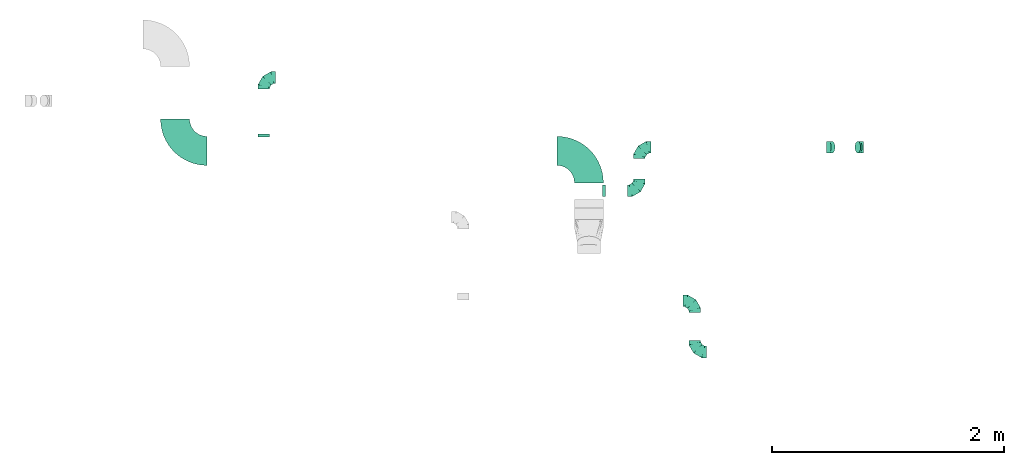
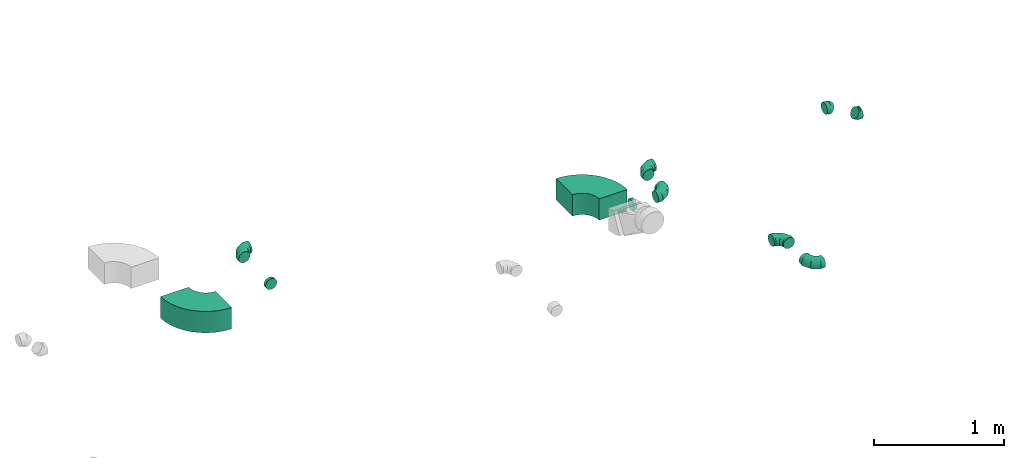
# One storey, part 26 of 32: 11 flow fittings.
"""IFC2X3 building model written with IfcOpenShell, lengths in millimetres."""

from ifc_helpers import new_model, entity, si_unit, converted_unit, derived_unit, direction, frame, frame_2d, origin, place, context, subcontext, project, spatial, polyline, circle_curve, parameter, trimmed, segment, composite_curve, outline, extrude, faceted_brep, source, transform, mapped, material, type_object, type_shapes, element, save


model = new_model("IFC2X3")

# Units and contexts
model_context = context("Model", 3, precision=0.01, world=origin(), true_north=direction((6.12303176911189e-17, 1.0)))
body_context = subcontext(model_context, "Body", "Model", "MODEL_VIEW")
ifc_project = project(units=[si_unit("LENGTHUNIT", "METRE", prefix="MILLI"), si_unit("AREAUNIT", "SQUARE_METRE"), si_unit("VOLUMEUNIT", "CUBIC_METRE"), converted_unit("PLANEANGLEUNIT", "DEGREE", entity("IfcRatioMeasure", 0.0174532925199433), si_unit("PLANEANGLEUNIT", "RADIAN"), dimensions=[0, 0, 0, 0, 0, 0, 0]), si_unit("MASSUNIT", "GRAM", prefix="KILO"), derived_unit("MASSDENSITYUNIT", [(si_unit("MASSUNIT", "GRAM", prefix="KILO"), 1), (si_unit("LENGTHUNIT", "METRE"), -3)]), derived_unit("MOMENTOFINERTIAUNIT", [(si_unit("LENGTHUNIT", "METRE"), 4)]), si_unit("TIMEUNIT", "SECOND"), si_unit("FREQUENCYUNIT", "HERTZ"), si_unit("THERMODYNAMICTEMPERATUREUNIT", "DEGREE_CELSIUS"), derived_unit("THERMALTRANSMITTANCEUNIT", [(si_unit("MASSUNIT", "GRAM", prefix="KILO"), 1), (si_unit("THERMODYNAMICTEMPERATUREUNIT", "KELVIN"), -1), (si_unit("TIMEUNIT", "SECOND"), -3)]), derived_unit("VOLUMETRICFLOWRATEUNIT", [(si_unit("LENGTHUNIT", "METRE"), 3), (si_unit("TIMEUNIT", "SECOND"), -1)]), derived_unit("MASSFLOWRATEUNIT", [(si_unit("MASSUNIT", "GRAM", prefix="KILO"), 1), (si_unit("TIMEUNIT", "SECOND"), -1)]), derived_unit("ROTATIONALFREQUENCYUNIT", [(si_unit("TIMEUNIT", "SECOND"), -1)]), si_unit("ELECTRICCURRENTUNIT", "AMPERE"), si_unit("ELECTRICVOLTAGEUNIT", "VOLT"), si_unit("POWERUNIT", "WATT"), si_unit("FORCEUNIT", "NEWTON", prefix="KILO"), si_unit("ILLUMINANCEUNIT", "LUX"), si_unit("LUMINOUSFLUXUNIT", "LUMEN"), si_unit("LUMINOUSINTENSITYUNIT", "CANDELA"), derived_unit("USERDEFINED", [(si_unit("MASSUNIT", "GRAM", prefix="KILO"), -1), (si_unit("LENGTHUNIT", "METRE"), -2), (si_unit("TIMEUNIT", "SECOND"), 3), (si_unit("LUMINOUSFLUXUNIT", "LUMEN"), 1)]), derived_unit("LINEARVELOCITYUNIT", [(si_unit("LENGTHUNIT", "METRE"), 1), (si_unit("TIMEUNIT", "SECOND"), -1)]), si_unit("PRESSUREUNIT", "PASCAL"), derived_unit("USERDEFINED", [(si_unit("LENGTHUNIT", "METRE"), -2), (si_unit("MASSUNIT", "GRAM", prefix="KILO"), 1), (si_unit("TIMEUNIT", "SECOND"), -2)]), derived_unit("LINEARFORCEUNIT", [(si_unit("MASSUNIT", "GRAM", prefix="KILO"), 1), (si_unit("LENGTHUNIT", "METRE"), 1), (si_unit("TIMEUNIT", "SECOND"), -2), (si_unit("LENGTHUNIT", "METRE"), -1)]), derived_unit("PLANARFORCEUNIT", [(si_unit("MASSUNIT", "GRAM", prefix="KILO"), 1), (si_unit("LENGTHUNIT", "METRE"), 1), (si_unit("TIMEUNIT", "SECOND"), -2), (si_unit("LENGTHUNIT", "METRE"), -2)])], contexts=[model_context])

# Site, building, storey
site_placement = place(None, origin())
site = spatial("IfcSite", under=ifc_project, at=site_placement, CompositionType="ELEMENT")
building_placement = place(site_placement, origin())
building = spatial("IfcBuilding", under=site, at=building_placement, CompositionType="ELEMENT")
storey_placement = place(building_placement, frame((0.0, 0.0, 8100.0)))
storey = spatial("IfcBuildingStorey", under=building, at=storey_placement, CompositionType="ELEMENT", Elevation=8100.0)

# Flow fittings
ifc_material = material()
duct_fitting_type_1 = type_object("IfcDuctFittingType", PredefinedType="NOTDEFINED", material=ifc_material)
shared_shape_1 = source(origin(), body_context, "Body", "Brep", [
    faceted_brep([(-100.0, 0.0, -50.0), (-100.0, -12.94, -48.3), (-100.0, -25.0, -43.3), (-100.0, -35.36, -35.36), (-100.0, -43.3, -25.0), (-100.0, -48.3, -12.94), (-100.0, -50.0, 0.0), (-100.0, -48.3, 12.94), (-100.0, -43.3, 25.0), (-100.0, -35.36, 35.36), (-100.0, -25.0, 43.3), (-100.0, -12.94, 48.3), (-100.0, 0.0, 50.0), (-100.0, 12.94, 48.3), (-100.0, 25.0, 43.3), (-100.0, 35.36, 35.36), (-100.0, 43.3, 25.0), (-100.0, 48.3, 12.94), (-100.0, 50.0, 0.0), (-100.0, 48.3, -12.94), (-100.0, 43.3, -25.0), (-100.0, 35.36, -35.36), (-100.0, 25.0, -43.3), (-100.0, 12.94, -48.3), (-76.67, 12.94, 48.3), (-79.9, 25.0, 43.3), (-73.21, 0.0, 50.0), (-82.68, 35.36, 35.36), (-86.15, 48.3, 12.94), (-86.6, 50.0, 0.0), (-84.81, 43.3, 25.0), (-84.81, 43.3, -25.0), (-82.68, 35.36, -35.36), (-86.15, 48.3, -12.94), (-76.67, 12.94, -48.3), (-73.21, 0.0, -50.0), (-79.9, 25.0, -43.3), (-69.74, -12.94, -48.3), (-66.51, -25.0, -43.3), (-63.73, -35.36, -35.36), (-61.6, -43.3, -25.0), (-60.26, -48.3, -12.94), (-59.81, -50.0, 0.0), (-60.26, -48.3, 12.94), (-61.6, -43.3, 25.0), (-63.73, -35.36, 35.36), (-66.51, -25.0, 43.3), (-69.74, -12.94, 48.3), (-36.27, 36.27, 48.3), (-45.1, 45.1, 43.3), (-26.79, 26.79, 50.0), (-52.68, 52.68, 35.36), (-58.49, 58.49, 25.0), (-62.15, 62.15, 12.94), (-63.4, 63.4, 0.0), (-62.15, 62.15, -12.94), (-58.49, 58.49, -25.0), (-52.68, 52.68, -35.36), (-36.27, 36.27, -48.3), (-26.79, 26.79, -50.0), (-45.1, 45.1, -43.3), (-17.32, 17.32, -48.3), (-8.49, 8.49, -43.3), (-0.91, 0.91, -35.36), (4.9, -4.9, -25.0), (8.56, -8.56, -12.94), (9.81, -9.81, 0.0), (8.56, -8.56, 12.94), (4.9, -4.9, 25.0), (-0.91, 0.91, 35.36), (-8.49, 8.49, 43.3), (-17.32, 17.32, 48.3), (-12.94, 76.67, 48.3), (-25.0, 79.9, 43.3), (0.0, 73.21, 50.0), (-35.36, 82.68, 35.36), (-43.3, 84.81, 25.0), (-48.3, 86.15, 12.94), (-50.0, 86.6, 0.0), (-48.3, 86.15, -12.94), (-43.3, 84.81, -25.0), (-35.36, 82.68, -35.36), (-12.94, 76.67, -48.3), (0.0, 73.21, -50.0), (-25.0, 79.9, -43.3), (12.94, 69.74, -48.3), (25.0, 66.51, -43.3), (35.36, 63.73, -35.36), (43.3, 61.6, -25.0), (48.3, 60.26, -12.94), (50.0, 59.81, 0.0), (48.3, 60.26, 12.94), (43.3, 61.6, 25.0), (35.36, 63.73, 35.36), (25.0, 66.51, 43.3), (12.94, 69.74, 48.3), (-12.94, 100.0, -48.3), (-25.0, 100.0, -43.3), (-35.36, 100.0, -35.36), (-43.3, 100.0, -25.0), (-48.3, 100.0, -12.94), (-50.0, 100.0, 0.0), (-48.3, 100.0, 12.94), (-43.3, 100.0, 25.0), (-35.36, 100.0, 35.36), (-25.0, 100.0, 43.3), (-12.94, 100.0, 48.3), (0.0, 100.0, 50.0), (12.94, 100.0, 48.3), (25.0, 100.0, 43.3), (35.36, 100.0, 35.36), (43.3, 100.0, 25.0), (48.3, 100.0, 12.94), (50.0, 100.0, 0.0), (48.3, 100.0, -12.94), (43.3, 100.0, -25.0), (35.36, 100.0, -35.36), (25.0, 100.0, -43.3), (12.94, 100.0, -48.3), (0.0, 100.0, -50.0)], [[[0, 1, 2, 3, 4, 5, 6, 7, 8, 9, 10, 11, 12, 13, 14, 15, 16, 17, 18, 19, 20, 21, 22, 23]], [[24, 25, 14, 13]], [[26, 24, 13, 12]], [[14, 25, 27, 15]], [[28, 29, 18, 17]], [[30, 28, 17, 16]], [[15, 27, 30, 16]], [[20, 31, 32, 21]], [[33, 31, 20, 19]], [[18, 29, 33, 19]], [[34, 35, 0, 23]], [[36, 34, 23, 22]], [[32, 36, 22, 21]], [[2, 1, 37, 38]], [[3, 2, 38, 39]], [[0, 35, 37, 1]], [[5, 4, 40, 41]], [[6, 5, 41, 42]], [[3, 39, 40, 4]], [[6, 42, 43, 7]], [[7, 43, 44, 8]], [[8, 44, 45, 9]], [[10, 46, 47, 11]], [[11, 47, 26, 12]], [[10, 9, 45, 46]], [[48, 49, 25, 24]], [[50, 48, 24, 26]], [[27, 25, 49, 51]], [[52, 53, 28, 30]], [[51, 52, 30, 27]], [[29, 28, 53, 54]], [[55, 56, 31, 33]], [[54, 55, 33, 29]], [[57, 32, 31, 56]], [[58, 59, 35, 34]], [[60, 58, 34, 36]], [[57, 60, 36, 32]], [[37, 35, 59, 61]], [[38, 37, 61, 62]], [[39, 38, 62, 63]], [[41, 40, 64, 65]], [[42, 41, 65, 66]], [[63, 64, 40, 39]], [[43, 42, 66, 67]], [[44, 43, 67, 68]], [[68, 69, 45, 44]], [[46, 45, 69, 70]], [[47, 46, 70, 71]], [[26, 47, 71, 50]], [[72, 73, 49, 48]], [[74, 72, 48, 50]], [[51, 49, 73, 75]], [[76, 77, 53, 52]], [[75, 76, 52, 51]], [[54, 53, 77, 78]], [[79, 80, 56, 55]], [[78, 79, 55, 54]], [[81, 57, 56, 80]], [[82, 83, 59, 58]], [[84, 82, 58, 60]], [[81, 84, 60, 57]], [[61, 59, 83, 85]], [[62, 61, 85, 86]], [[63, 62, 86, 87]], [[65, 64, 88, 89]], [[66, 65, 89, 90]], [[87, 88, 64, 63]], [[67, 66, 90, 91]], [[68, 67, 91, 92]], [[92, 93, 69, 68]], [[70, 69, 93, 94]], [[71, 70, 94, 95]], [[50, 71, 95, 74]], [[96, 97, 98, 99, 100, 101, 102, 103, 104, 105, 106, 107, 108, 109, 110, 111, 112, 113, 114, 115, 116, 117, 118, 119]], [[72, 74, 107, 106]], [[73, 72, 106, 105]], [[75, 73, 105, 104]], [[77, 76, 103, 102]], [[78, 77, 102, 101]], [[75, 104, 103, 76]], [[78, 101, 100, 79]], [[79, 100, 99, 80]], [[80, 99, 98, 81]], [[96, 119, 83, 82]], [[97, 96, 82, 84]], [[84, 81, 98, 97]], [[83, 119, 118, 85]], [[85, 118, 117, 86]], [[86, 117, 116, 87]], [[88, 115, 114, 89]], [[89, 114, 113, 90]], [[87, 116, 115, 88]], [[91, 90, 113, 112]], [[92, 91, 112, 111]], [[93, 92, 111, 110]], [[95, 94, 109, 108]], [[74, 95, 108, 107]], [[110, 109, 94, 93]]]),
])
type_shapes(duct_fitting_type_1, [shared_shape_1])
for number, where, z_axis, x_axis in (
    (1, (61787.3, 17678.1, 3300.0), (0.0, 0.0, 1.0), (0.0, 1.0, 0.0)),
    (2, (61787.3, 17238.1, 3300.0), (0.0, 0.0, 1.0), (0.0, -1.0, 0.0)),
    (3, (58070.82, 19604.79, 3300.0), (0.0, 0.0, 1.0), (-1.0, 0.0, 0.0)),
    (4, (61308.84, 19004.55, 3300.0), (0.0, 0.0, 1.0), (-1.0, 0.0, 0.0)),
):
    element("IfcFlowFitting", number, at=place(storey_placement, frame(where, z_axis=z_axis, x_axis=x_axis)), inside=storey, type_object=duct_fitting_type_1, material=ifc_material, context=body_context, shape_type="MappedRepresentation", body=[
        mapped(shared_shape_1, transform((0.0, 0.0, 0.0), scale=1.0)),
    ])
flow_fitting_1_placement = place(storey_placement, frame((61308.84, 18629.55, 3300.0)))
element("IfcFlowFitting", 5, at=flow_fitting_1_placement, inside=storey, type_object=duct_fitting_type_1, material=ifc_material, context=body_context, shape_type="MappedRepresentation", body=[
    mapped(shared_shape_1, transform((0.0, 0.0, 0.0), scale=1.0)),
])
duct_fitting_type_2 = type_object("IfcDuctFittingType", PredefinedType="NOTDEFINED", material=ifc_material)
shared_shape_2 = source(origin(), body_context, "Body", "Brep", [
    faceted_brep([(20.0, 0.0, -50.0), (20.0, 12.94, -48.3), (20.0, 25.0, -43.3), (20.0, 35.36, -35.36), (20.0, 43.3, -25.0), (20.0, 48.3, -12.94), (20.0, 50.0, 0.0), (20.0, 48.3, 12.94), (20.0, 43.3, 25.0), (20.0, 35.36, 35.36), (20.0, 25.0, 43.3), (20.0, 12.94, 48.3), (20.0, 0.0, 50.0), (20.0, -12.94, 48.3), (20.0, -25.0, 43.3), (20.0, -35.36, 35.36), (20.0, -43.3, 25.0), (20.0, -48.3, 12.94), (20.0, -50.0, 0.0), (20.0, -48.3, -12.94), (20.0, -43.3, -25.0), (20.0, -35.36, -35.36), (20.0, -25.0, -43.3), (20.0, -12.94, -48.3), (0.0, 0.0, 50.0), (-6.1, 0.0, 50.0), (-6.1, -12.94, 48.3), (0.0, -12.94, 48.3), (-6.1, -25.0, 43.3), (0.0, -25.0, 43.3), (0.0, -35.36, 35.36), (-6.1, -35.36, 35.36), (0.0, -43.3, 25.0), (-6.1, -43.3, 25.0), (-6.1, -48.3, 12.94), (0.0, -48.3, 12.94), (-6.1, -50.0, 0.0), (0.0, -50.0, 0.0), (-6.1, -48.3, -12.94), (0.0, -48.3, -12.94), (-6.1, -43.3, -25.0), (0.0, -43.3, -25.0), (0.0, -35.36, -35.36), (-6.1, -35.36, -35.36), (0.0, -25.0, -43.3), (-6.1, -25.0, -43.3), (-6.1, -12.94, -48.3), (0.0, -12.94, -48.3), (-6.1, 0.0, -50.0), (0.0, 0.0, -50.0), (-6.1, 12.94, -48.3), (0.0, 12.94, -48.3), (-6.1, 25.0, -43.3), (0.0, 25.0, -43.3), (0.0, 35.36, -35.36), (-6.1, 35.36, -35.36), (0.0, 43.3, -25.0), (-6.1, 43.3, -25.0), (-6.1, 48.3, -12.94), (0.0, 48.3, -12.94), (-6.1, 50.0, 0.0), (0.0, 50.0, 0.0), (-6.1, 48.3, 12.94), (0.0, 48.3, 12.94), (-6.1, 43.3, 25.0), (0.0, 43.3, 25.0), (0.0, 35.36, 35.36), (-6.1, 35.36, 35.36), (0.0, 25.0, 43.3), (-6.1, 25.0, 43.3), (-6.1, 12.94, 48.3), (0.0, 12.94, 48.3)], [[[0, 1, 2, 3, 4, 5, 6, 7, 8, 9, 10, 11, 12, 13, 14, 15, 16, 17, 18, 19, 20, 21, 22, 23]], [[13, 12, 24, 25, 26, 27]], [[14, 13, 27, 26, 28, 29]], [[30, 15, 14, 29, 28, 31]], [[17, 16, 32, 33, 34, 35]], [[18, 17, 35, 34, 36, 37]], [[32, 16, 15, 30, 31, 33]], [[19, 18, 37, 36, 38, 39]], [[20, 19, 39, 38, 40, 41]], [[42, 21, 20, 41, 40, 43]], [[23, 22, 44, 45, 46, 47]], [[0, 23, 47, 46, 48, 49]], [[44, 22, 21, 42, 43, 45]], [[1, 0, 49, 48, 50, 51]], [[2, 1, 51, 50, 52, 53]], [[54, 3, 2, 53, 52, 55]], [[5, 4, 56, 57, 58, 59]], [[6, 5, 59, 58, 60, 61]], [[56, 4, 3, 54, 55, 57]], [[7, 6, 61, 60, 62, 63]], [[8, 7, 63, 62, 64, 65]], [[66, 9, 8, 65, 64, 67]], [[11, 10, 68, 69, 70, 71]], [[12, 11, 71, 70, 25, 24]], [[68, 10, 9, 66, 67, 69]], [[46, 45, 43, 40, 38, 36, 34, 33, 31, 28, 26, 25, 70, 69, 67, 64, 62, 60, 58, 57, 55, 52, 50, 48]]]),
])
type_shapes(duct_fitting_type_2, [shared_shape_2])
flow_fitting_2_placement = place(storey_placement, frame((60998.84, 18629.55, 3300.0), z_axis=(0.0, 0.0, -1.0), x_axis=(1.0, 0.0, 0.0)))
element("IfcFlowFitting", 6, at=flow_fitting_2_placement, inside=storey, type_object=duct_fitting_type_2, material=ifc_material, context=body_context, shape_type="MappedRepresentation", body=[
    mapped(shared_shape_2, transform((0.0, 0.0, 0.0), scale=1.0)),
])
duct_fitting_type_3 = type_object("IfcDuctFittingType", PredefinedType="NOTDEFINED", material=ifc_material)
shared_shape_3 = source(origin(), body_context, "Body", "Brep", [
    faceted_brep([(-25.86, 0.0, -50.0), (-25.86, -12.94, -48.3), (-25.86, -25.0, -43.3), (-25.86, -35.36, -35.36), (-25.86, -43.3, -25.0), (-25.86, -48.3, -12.94), (-25.86, -50.0, 0.0), (-25.86, -48.3, 12.94), (-25.86, -43.3, 25.0), (-25.86, -35.36, 35.36), (-25.86, -25.0, 43.3), (-25.86, -12.94, 48.3), (-25.86, 0.0, 50.0), (-25.86, 12.94, 48.3), (-25.86, 25.0, 43.3), (-25.86, 35.36, 35.36), (-25.86, 43.3, 25.0), (-25.86, 48.3, 12.94), (-25.86, 50.0, 0.0), (-25.86, 48.3, -12.94), (-25.86, 43.3, -25.0), (-25.86, 35.36, -35.36), (-25.86, 25.0, -43.3), (-25.86, 12.94, -48.3), (-3.35, 12.94, 48.3), (-6.47, 25.0, 43.3), (0.0, 0.0, 50.0), (-9.14, 35.36, 35.36), (-12.49, 48.3, 12.94), (-12.93, 50.0, 0.0), (-11.2, 43.3, 25.0), (-11.2, 43.3, -25.0), (-9.14, 35.36, -35.36), (-12.49, 48.3, -12.94), (-3.35, 12.94, -48.3), (0.0, 0.0, -50.0), (-6.47, 25.0, -43.3), (3.35, -12.94, -48.3), (6.47, -25.0, -43.3), (9.14, -35.36, -35.36), (11.2, -43.3, -25.0), (12.49, -48.3, -12.94), (12.93, -50.0, 0.0), (12.49, -48.3, 12.94), (11.2, -43.3, 25.0), (9.14, -35.36, 35.36), (6.47, -25.0, 43.3), (3.35, -12.94, 48.3), (22.62, 12.54, 50.0), (16.35, 23.86, 48.3), (10.5, 34.4, 43.3), (5.48, 43.46, 35.36), (1.63, 50.41, 25.0), (-0.8, 54.78, 12.94), (-1.62, 56.27, 0.0), (-0.8, 54.78, -12.94), (1.63, 50.41, -25.0), (5.48, 43.46, -35.36), (16.35, 23.86, -48.3), (22.62, 12.54, -50.0), (10.5, 34.4, -43.3), (28.89, 1.22, -48.3), (34.74, -9.33, -43.3), (39.76, -18.38, -35.36), (43.61, -25.33, -25.0), (46.03, -29.7, -12.94), (46.86, -31.19, 0.0), (46.03, -29.7, 12.94), (43.61, -25.33, 25.0), (39.76, -18.38, 35.36), (28.89, 1.22, 48.3), (34.74, -9.33, 43.3)], [[[0, 1, 2, 3, 4, 5, 6, 7, 8, 9, 10, 11, 12, 13, 14, 15, 16, 17, 18, 19, 20, 21, 22, 23]], [[24, 25, 14, 13]], [[26, 24, 13, 12]], [[14, 25, 27, 15]], [[28, 29, 18, 17]], [[30, 28, 17, 16]], [[15, 27, 30, 16]], [[20, 31, 32, 21]], [[33, 31, 20, 19]], [[18, 29, 33, 19]], [[34, 35, 0, 23]], [[36, 34, 23, 22]], [[32, 36, 22, 21]], [[2, 1, 37, 38]], [[3, 2, 38, 39]], [[0, 35, 37, 1]], [[5, 4, 40, 41]], [[6, 5, 41, 42]], [[3, 39, 40, 4]], [[6, 42, 43, 7]], [[7, 43, 44, 8]], [[8, 44, 45, 9]], [[10, 46, 47, 11]], [[11, 47, 26, 12]], [[9, 45, 46, 10]], [[24, 26, 48, 49]], [[25, 24, 49, 50]], [[27, 25, 50, 51]], [[28, 30, 52, 53]], [[29, 28, 53, 54]], [[27, 51, 52, 30]], [[29, 54, 55, 33]], [[33, 55, 56, 31]], [[31, 56, 57, 32]], [[58, 59, 35, 34]], [[60, 58, 34, 36]], [[36, 32, 57, 60]], [[35, 59, 61, 37]], [[37, 61, 62, 38]], [[38, 62, 63, 39]], [[40, 64, 65, 41]], [[41, 65, 66, 42]], [[39, 63, 64, 40]], [[43, 42, 66, 67]], [[44, 43, 67, 68]], [[45, 44, 68, 69]], [[70, 48, 26, 47]], [[71, 70, 47, 46]], [[69, 71, 46, 45]], [[58, 60, 57, 56, 55, 54, 53, 52, 51, 50, 49, 48, 70, 71, 69, 68, 67, 66, 65, 64, 63, 62, 61, 59]]]),
])
type_shapes(duct_fitting_type_3, [shared_shape_3])
for number, where, z_axis, x_axis in (
    (7, (63215.6, 19004.55, 3152.13), (0.0, -1.0, 0.0), (0.874619707139384, 0.0, -0.484809620246359)),
    (8, (62948.84, 19004.55, 3300.0), (0.0, -1.0, 0.0), (-0.874619707139371, 0.0, 0.484809620246381)),
):
    element("IfcFlowFitting", number, at=place(storey_placement, frame(where, z_axis=z_axis, x_axis=x_axis)), inside=storey, type_object=duct_fitting_type_3, material=ifc_material, context=body_context, shape_type="MappedRepresentation", body=[
        mapped(shared_shape_3, transform((0.0, 0.0, 0.0), scale=1.0)),
    ])
duct_fitting_type_4 = type_object("IfcDuctFittingType", PredefinedType="NOTDEFINED", material=ifc_material)
shared_shape_4 = source(origin(), body_context, "Body", "Brep", [
    faceted_brep([(20.0, 12.94, -48.3), (20.0, 25.0, -43.3), (20.0, 35.36, -35.36), (20.0, 43.3, -25.0), (20.0, 48.3, -12.94), (20.0, 50.0, 0.0), (20.0, 48.3, 12.94), (20.0, 43.3, 25.0), (20.0, 35.36, 35.36), (20.0, 25.0, 43.3), (20.0, 12.94, 48.3), (20.0, 0.0, 50.0), (20.0, -12.94, 48.3), (20.0, -25.0, 43.3), (20.0, -35.36, 35.36), (20.0, -43.3, 25.0), (20.0, -48.3, 12.94), (20.0, -50.0, 0.0), (20.0, -48.3, -12.94), (20.0, -43.3, -25.0), (20.0, -35.36, -35.36), (20.0, -25.0, -43.3), (20.0, -12.94, -48.3), (20.0, 0.0, -50.0), (0.0, 0.0, 50.0), (0.0, 12.94, 48.3), (-6.1, 12.94, 48.3), (-6.1, 0.0, 50.0), (0.0, 25.0, 43.3), (-6.1, 25.0, 43.3), (0.0, 35.36, 35.36), (-6.1, 35.36, 35.36), (0.0, 43.3, 25.0), (0.0, 48.3, 12.94), (-6.1, 48.3, 12.94), (-6.1, 43.3, 25.0), (0.0, 50.0, 0.0), (-6.1, 50.0, 0.0), (0.0, 48.3, -12.94), (-6.1, 48.3, -12.94), (0.0, 43.3, -25.0), (-6.1, 43.3, -25.0), (0.0, 35.36, -35.36), (-6.1, 35.36, -35.36), (0.0, 25.0, -43.3), (0.0, 12.94, -48.3), (-6.1, 12.94, -48.3), (-6.1, 25.0, -43.3), (0.0, 0.0, -50.0), (-6.1, 0.0, -50.0), (0.0, -12.94, -48.3), (-6.1, -12.94, -48.3), (0.0, -25.0, -43.3), (-6.1, -25.0, -43.3), (0.0, -35.36, -35.36), (-6.1, -35.36, -35.36), (0.0, -43.3, -25.0), (0.0, -48.3, -12.94), (-6.1, -48.3, -12.94), (-6.1, -43.3, -25.0), (0.0, -50.0, 0.0), (-6.1, -50.0, 0.0), (0.0, -48.3, 12.94), (-6.1, -48.3, 12.94), (0.0, -43.3, 25.0), (-6.1, -43.3, 25.0), (0.0, -35.36, 35.36), (-6.1, -35.36, 35.36), (0.0, -25.0, 43.3), (0.0, -12.94, 48.3), (-6.1, -12.94, 48.3), (-6.1, -25.0, 43.3)], [[[0, 1, 2, 3, 4, 5, 6, 7, 8, 9, 10, 11, 12, 13, 14, 15, 16, 17, 18, 19, 20, 21, 22, 23]], [[24, 11, 10, 25, 26, 27]], [[25, 10, 9, 28, 29, 26]], [[28, 9, 8, 30, 31, 29]], [[32, 7, 6, 33, 34, 35]], [[33, 6, 5, 36, 37, 34]], [[30, 8, 7, 32, 35, 31]], [[36, 5, 4, 38, 39, 37]], [[38, 4, 3, 40, 41, 39]], [[40, 3, 2, 42, 43, 41]], [[44, 1, 0, 45, 46, 47]], [[45, 0, 23, 48, 49, 46]], [[42, 2, 1, 44, 47, 43]], [[48, 23, 22, 50, 51, 49]], [[50, 22, 21, 52, 53, 51]], [[52, 21, 20, 54, 55, 53]], [[56, 19, 18, 57, 58, 59]], [[57, 18, 17, 60, 61, 58]], [[54, 20, 19, 56, 59, 55]], [[60, 17, 16, 62, 63, 61]], [[62, 16, 15, 64, 65, 63]], [[64, 15, 14, 66, 67, 65]], [[68, 13, 12, 69, 70, 71]], [[69, 12, 11, 24, 27, 70]], [[66, 14, 13, 68, 71, 67]], [[49, 51, 53, 55, 59, 58, 61, 63, 65, 67, 71, 70, 27, 26, 29, 31, 35, 34, 37, 39, 41, 43, 47, 46]]]),
])
type_shapes(duct_fitting_type_4, [shared_shape_4])
flow_fitting_3_placement = place(storey_placement, frame((58070.82, 19097.07, 3300.0), z_axis=(0.0, 0.0, -1.0), x_axis=(0.0, 1.0, 0.0)))
element("IfcFlowFitting", 9, at=flow_fitting_3_placement, inside=storey, type_object=duct_fitting_type_4, material=ifc_material, context=body_context, shape_type="MappedRepresentation", body=[
    mapped(shared_shape_4, transform((0.0, 0.0, 0.0), scale=1.0)),
])
duct_fitting_type_5 = type_object("IfcDuctFittingType", PredefinedType="NOTDEFINED", material=ifc_material)
shared_shape_5 = source(origin(), body_context, "Body", "SweptSolid", [
    extrude(outline(composite_curve([segment(polyline([(-262.5, -137.5), (-12.5, -137.5)]), True, "CONTINUOUS"), segment(trimmed(circle_curve(frame_2d((137.5, -137.5), x_axis=(0.0, 1.0)), 150.0), [parameter(0.0)], [parameter(90.0000000000001)], True, "PARAMETER"), False, "CONTINUOUS"), segment(polyline([(137.5, 12.5), (137.5, 262.5)]), True, "CONTINUOUS"), segment(trimmed(circle_curve(frame_2d((137.5, -137.5), x_axis=(0.0, 1.0)), 400.0), [parameter(0.0)], [parameter(90.0000000000001)], True, "PARAMETER"), True, "CONTINUOUS")], self_intersect=False)), frame((-137.5, 137.5, -100.0), z_axis=(0.0, 0.0, 1.0), x_axis=(-1.0, 0.0, 0.0)), (0.0, 0.0, 1.0), 200.0),
])
type_shapes(duct_fitting_type_5, [shared_shape_5])
for number, where, z_axis, x_axis in (
    (10, (60873.84, 18972.07, 3300.0), (0.0, 0.0, 1.0), (0.0, 1.0, 0.0)),
    (11, (57304.84, 18972.07, 3300.0), (0.0, 0.0, 1.0), (0.0, -1.0, 0.0)),
):
    element("IfcFlowFitting", number, at=place(storey_placement, frame(where, z_axis=z_axis, x_axis=x_axis)), inside=storey, type_object=duct_fitting_type_5, material=ifc_material, context=body_context, shape_type="MappedRepresentation", body=[
        mapped(shared_shape_5, transform((0.0, 0.0, 0.0), scale=1.0)),
    ])

save(model, "model.ifc")
